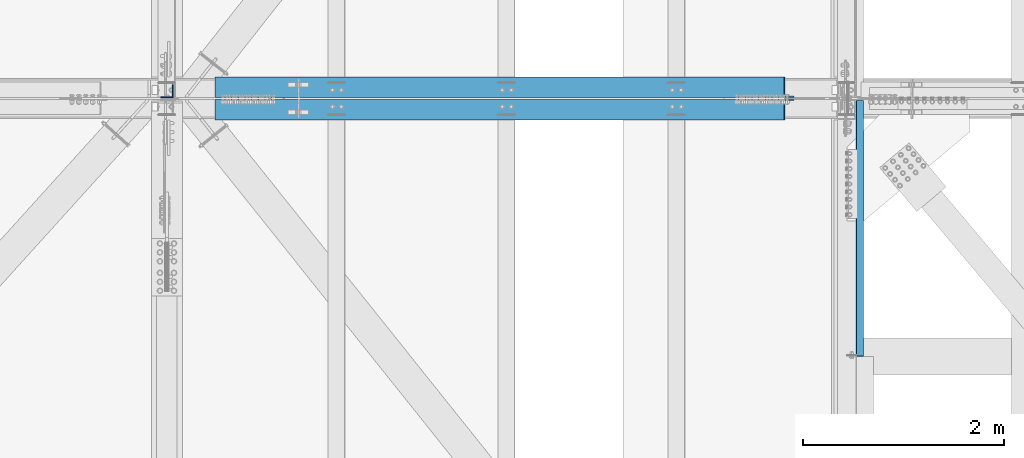
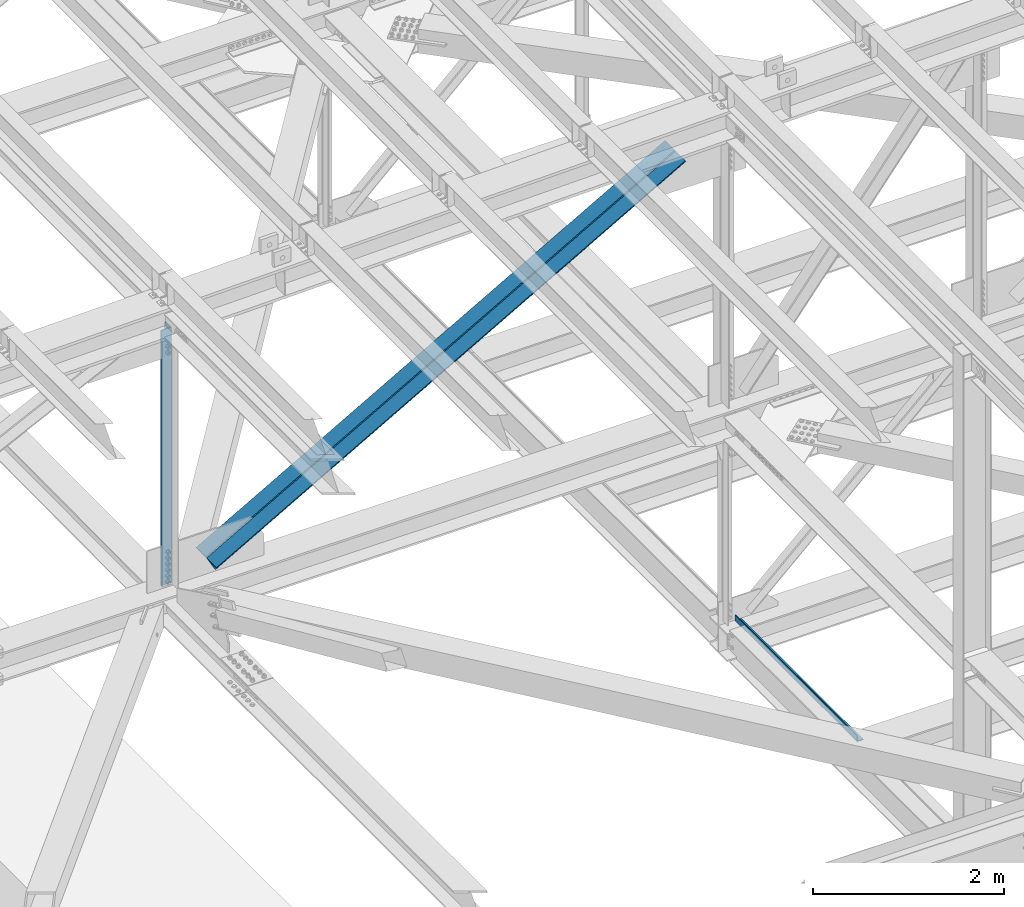
# One storey, part 1833 of 3843: 2 beams, 2 members, 4 elements without a shape of their own.
"""IFC2X3 building model written with IfcOpenShell, lengths in millimetres."""

from ifc_helpers import new_model, si_unit, frame, origin_with_axes, place, context, subcontext, project, spatial, faceted_brep, material, type_object, element, aggregate, save


model = new_model("IFC2X3")

# Units and contexts
model_context = context("Model", 3, precision=1e-05, world=origin_with_axes())
body_context = subcontext(model_context, "Body", "Model", "MODEL_VIEW")
ifc_project = project(units=[si_unit("LENGTHUNIT", "METRE", prefix="MILLI"), si_unit("AREAUNIT", "SQUARE_METRE"), si_unit("VOLUMEUNIT", "CUBIC_METRE"), si_unit("MASSUNIT", "GRAM", prefix="KILO"), si_unit("TIMEUNIT", "SECOND"), si_unit("PLANEANGLEUNIT", "RADIAN"), si_unit("SOLIDANGLEUNIT", "STERADIAN"), si_unit("THERMODYNAMICTEMPERATUREUNIT", "DEGREE_CELSIUS"), si_unit("LUMINOUSINTENSITYUNIT", "LUMEN")], contexts=[model_context])

# Site, building, storey
site_placement = place(None, origin_with_axes())
site = spatial("IfcSite", under=ifc_project, at=site_placement, CompositionType="ELEMENT")
building_placement = place(site_placement, origin_with_axes())
building = spatial("IfcBuilding", under=site, at=building_placement, Name="Undefined", CompositionType="ELEMENT")
storey_placement = place(building_placement, origin_with_axes())
storey = spatial("IfcBuildingStorey", under=building, at=storey_placement, Name="Undefined", CompositionType="ELEMENT", Elevation=0.0)

# Assembly, beam
assembly_1_placement = place(storey_placement, origin_with_axes())
assembly_1 = element("IfcElementAssembly", 1, at=assembly_1_placement, inside=storey, Name="BENT_PLATE", AssemblyPlace="NOTDEFINED", PredefinedType="RIGID_FRAME")
ifc_material_1 = material(Name="STEEL/A36")
beam_type_1 = type_object("IfcBeamType", PredefinedType="NOTDEFINED")
beam_1_placement = place(assembly_1_placement, frame((77179.4875000003, 32553.275, 39627.1749999989), z_axis=(0.0, 1.0, 0.0), x_axis=(-1.0, 0.0, 0.0)))
beam_1 = element("IfcBeam", 2, at=beam_1_placement, type_object=beam_type_1, material=ifc_material_1, Name="BENT_PLATE", context=body_context, shape_type="Brep", body=[
    faceted_brep([(69.8500000001368, 3.17500000000291, -1270.00000004769), (73.0249999524531, 4.82395989820361e-08, -1273.175), (0.0, 4.82395989820361e-08, -1273.175), (0.0, 3.17500000000291, -1270.0000000477), (69.8500000002095, 73.0250000004089, -1270.00000004769), (73.0249999525258, 73.0250000004089, -1273.175), (0.0, 3.17500000000291, 1273.175), (69.8500000001368, 3.17500000000291, 1273.175), (0.0, -3.17500000000291, -1273.175), (0.0, -3.17500000000291, 1273.175), (76.200000000259, -3.17500000000291, -1273.175), (76.200000000259, -3.17500000000291, 1273.175), (69.8500000002095, 73.0250000004089, 1273.175), (76.2000000003463, 73.0249999997395, 1273.175), (76.2000000003463, 73.0249999997395, -1273.175)], [[[0, 1, 2, 3]], [[4, 5, 1, 0]], [[6, 7, 0, 3]], [[8, 9, 6, 3, 2]], [[9, 8, 10, 11]], [[7, 12, 4, 0]], [[7, 6, 9, 11, 13, 12]], [[11, 10, 14, 13]], [[5, 14, 10, 8, 2, 1]], [[12, 13, 14, 5, 4]]]),
])
aggregate(assembly_1, [beam_1])

assembly_2_placement = place(storey_placement, origin_with_axes())
assembly_2 = element("IfcElementAssembly", 3, at=assembly_2_placement, inside=storey, Name="ANGLE", AssemblyPlace="NOTDEFINED", PredefinedType="RIGID_FRAME")
ifc_material_2 = material(Name="STEEL/A572-50")
beam_type_2 = type_object("IfcBeamType", Name="L5X5X3/8", PredefinedType="NOTDEFINED")
beam_2_placement = place(assembly_2_placement, frame((70256.4, 33918.525, 45950.2996849465), z_axis=(-1.0, 0.0, 0.0), x_axis=(0.0, 0.0, -1.0)))
beam_2 = element("IfcBeam", 4, at=beam_2_placement, type_object=beam_type_2, material=ifc_material_2, Name="ANGLE", ObjectType="L5X5X3/8", context=body_context, shape_type="Brep", body=[
    faceted_brep([(223.003811397917, 63.5, -63.5), (223.003811397917, 63.5, 63.5), (3478.10685425474, 63.5, 63.5), (3478.10685425474, 63.5, -63.5), (223.003811397917, 53.9749999999985, 63.5), (3478.10685425474, 53.9749999999985, 63.5), (223.003811397917, 53.9749999999985, -53.9750000000058), (3478.10685425474, 53.9749999999985, -53.9750000000058), (223.003811397917, -63.5, -53.9750000000058), (3478.10685425474, -63.5, -53.9750000000058), (223.003811397917, -63.5, -63.5), (3478.10685425474, -63.5, -63.5)], [[[0, 1, 2, 3]], [[1, 4, 5, 2]], [[4, 6, 7, 5]], [[6, 8, 9, 7]], [[8, 10, 11, 9]], [[10, 0, 3, 11]], [[5, 7, 9, 11, 3, 2]], [[10, 8, 6, 4, 1, 0]]]),
])
aggregate(assembly_2, [beam_2])

# Assembly, member
assembly_3_placement = place(storey_placement, origin_with_axes())
assembly_3 = element("IfcElementAssembly", 5, at=assembly_3_placement, inside=storey, Name="ANGLE", AssemblyPlace="NOTDEFINED", PredefinedType="RIGID_FRAME")
member_type = type_object("IfcMemberType", Name="L8X8X1/2", PredefinedType="NOTDEFINED")
member_1_placement = place(assembly_3_placement, frame((77012.8000011244, 33956.625, 46096.5035392583), z_axis=(0.0, 1.0, 0.0), x_axis=(-0.869742351575414, 0.0, -0.493506070759084)))
member_1 = element("IfcMember", 6, at=member_1_placement, type_object=member_type, material=ifc_material_2, Name="ANGLE", ObjectType="L8X8X1/2", context=body_context, shape_type="Brep", body=[
    faceted_brep([(656.756706188433, 101.59999999938, -101.599999999999), (656.756706188433, 101.59999999938, 101.599999999999), (7164.04225873055, 101.599999989194, 101.599999999999), (7164.04225873055, 101.599999989194, -101.599999999999), (656.756706188404, 88.8999999993321, 101.599999999999), (7164.04225873051, 88.8999999891312, 101.599999999999), (656.756706188404, 88.8999999993321, -88.9000000000015), (7164.04225873051, 88.8999999891312, -88.9000000000015), (656.75670618788, -101.600000001439, -88.9000000000015), (7164.04225872998, -101.600000011633, -88.9000000000015), (656.75670618788, -101.600000001439, -101.599999999999), (7164.04225872998, -101.600000011633, -101.599999999999)], [[[0, 1, 2, 3]], [[1, 4, 5, 2]], [[4, 6, 7, 5]], [[6, 8, 9, 7]], [[8, 10, 11, 9]], [[10, 0, 3, 11]], [[5, 7, 9, 11, 3, 2]], [[10, 8, 6, 4, 1, 0]]]),
])
aggregate(assembly_3, [member_1])

assembly_4_placement = place(storey_placement, origin_with_axes())
assembly_4 = element("IfcElementAssembly", 7, at=assembly_4_placement, inside=storey, Name="ANGLE", AssemblyPlace="NOTDEFINED", PredefinedType="RIGID_FRAME")
member_2_placement = place(assembly_4_placement, frame((70256.4000025811, 33734.375, 42262.8114013223), z_axis=(0.0, -1.0, 0.0), x_axis=(0.869742351575413, 0.0, 0.493506070759085)))
member_2 = element("IfcMember", 8, at=member_2_placement, type_object=member_type, material=ifc_material_2, Name="ANGLE", ObjectType="L8X8X1/2", context=body_context, shape_type="Brep", body=[
    faceted_brep([(604.235307589086, 101.600000001368, -101.599999999999), (604.235307589086, 101.600000001368, 101.599999999999), (7111.52086013119, 101.600000011561, 101.599999999999), (7111.52086013119, 101.600000011561, -101.599999999999), (604.235307589115, 88.9000000013125, 101.599999999999), (7111.52086013122, 88.9000000115061, 101.599999999999), (604.235307589115, 88.9000000013125, -88.9000000000015), (7111.52086013122, 88.9000000115061, -88.9000000000015), (604.235307589639, -101.599999999473, -88.9000000000015), (7111.52086013174, -101.59999998928, -88.9000000000015), (604.235307589639, -101.599999999473, -101.599999999999), (7111.52086013174, -101.59999998928, -101.599999999999)], [[[0, 1, 2, 3]], [[1, 4, 5, 2]], [[4, 6, 7, 5]], [[6, 8, 9, 7]], [[8, 10, 11, 9]], [[10, 0, 3, 11]], [[5, 7, 9, 11, 3, 2]], [[10, 8, 6, 4, 1, 0]]]),
])
aggregate(assembly_4, [member_2])

save(model, "model.ifc")
